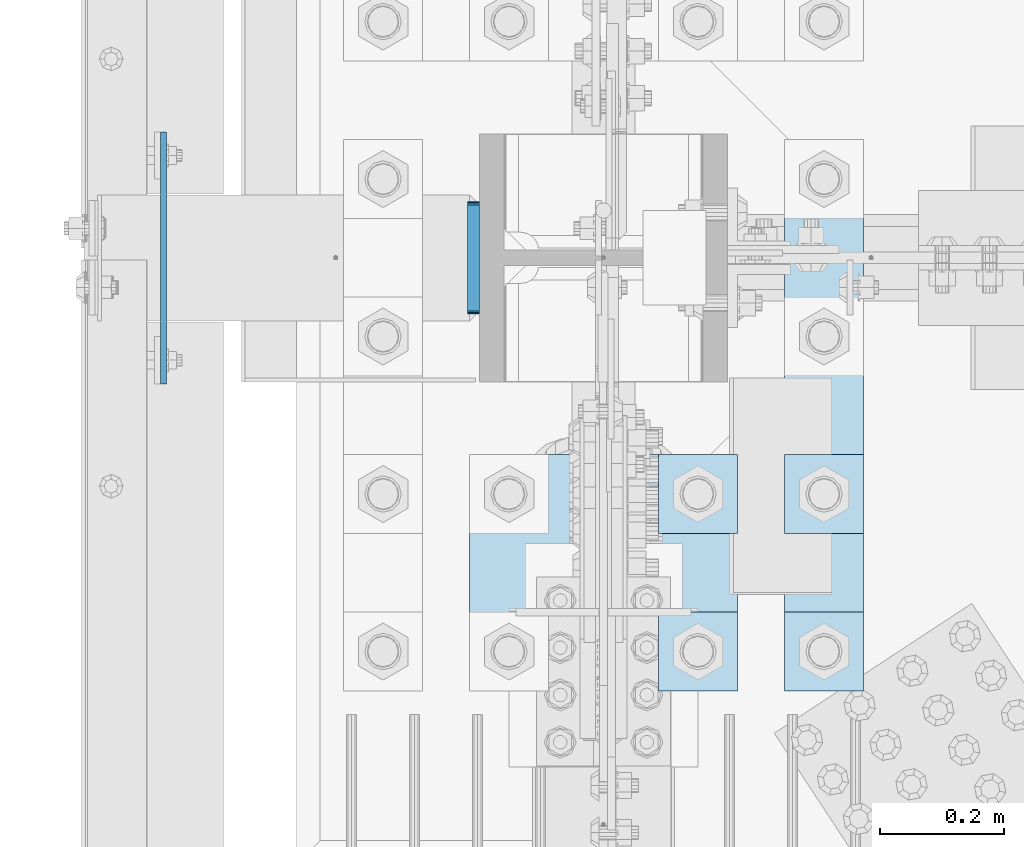
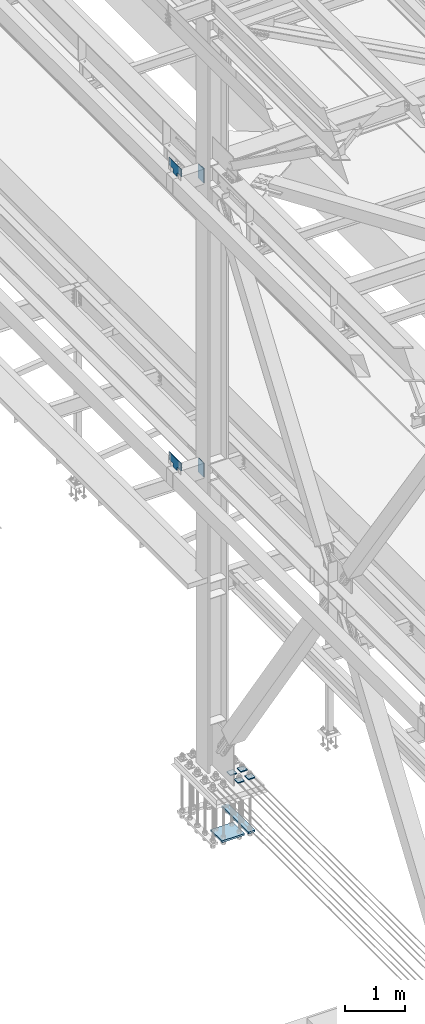
# One storey, part 3270 of 3843: 10 plates, 2 elements without a shape of their own.
"""IFC2X3 building model written with IfcOpenShell, lengths in millimetres."""

from ifc_helpers import new_model, si_unit, frame, origin_with_axes, place, context, subcontext, project, spatial, faceted_brep, material, type_object, element, aggregate, save


model = new_model("IFC2X3")

# Units and contexts
model_context = context("Model", 3, precision=1e-05, world=origin_with_axes())
body_context = subcontext(model_context, "Body", "Model", "MODEL_VIEW")
ifc_project = project(units=[si_unit("LENGTHUNIT", "METRE", prefix="MILLI"), si_unit("AREAUNIT", "SQUARE_METRE"), si_unit("VOLUMEUNIT", "CUBIC_METRE"), si_unit("MASSUNIT", "GRAM", prefix="KILO"), si_unit("TIMEUNIT", "SECOND"), si_unit("PLANEANGLEUNIT", "RADIAN"), si_unit("SOLIDANGLEUNIT", "STERADIAN"), si_unit("THERMODYNAMICTEMPERATUREUNIT", "DEGREE_CELSIUS"), si_unit("LUMINOUSINTENSITYUNIT", "LUMEN")], contexts=[model_context])

# Site, building, storey
site_placement = place(None, origin_with_axes())
site = spatial("IfcSite", under=ifc_project, at=site_placement, CompositionType="ELEMENT")
building_placement = place(site_placement, origin_with_axes())
building = spatial("IfcBuilding", under=site, at=building_placement, Name="Undefined", CompositionType="ELEMENT")
storey_placement = place(building_placement, origin_with_axes())
storey = spatial("IfcBuildingStorey", under=building, at=storey_placement, Name="Undefined", CompositionType="ELEMENT", Elevation=0.0)

# Assembly, plates
assembly_1_placement = place(storey_placement, origin_with_axes())
assembly_1 = element("IfcElementAssembly", 1, at=assembly_1_placement, inside=storey, Name="COLUMN", AssemblyPlace="NOTDEFINED", PredefinedType="RIGID_FRAME")
ifc_material = material(Name="STEEL/A572-50")
plate_type_1 = type_object("IfcPlateType", PredefinedType="NOTDEFINED")
plate_1_placement = place(assembly_1_placement, frame((35866.3875, 58978.8, 36404.55), z_axis=(0.0, 0.0, 1.0), x_axis=(0.0, -1.0, 0.0)))
plate_1 = element("IfcPlate", 2, at=plate_1_placement, type_object=plate_type_1, material=ifc_material, Name="PLATE", context=body_context, shape_type="Brep", body=[
    faceted_brep([(0.0, -4.76249999999709, 0.0), (-3.49245965480804e-10, -4.76249999999709, 76.1999999999462), (-3.49245965480804e-10, 4.76249999999709, 76.1999999999462), (0.0, 4.76249999999709, 0.0), (-139.699996948242, -4.76249999999709, 76.1999969482422), (-139.699996948242, 4.76249999999709, 76.1999969482422), (-139.699996948242, -4.76249999999709, 228.600006103516), (-139.699996948242, 4.76249999999709, 228.600006103516), (266.700012207031, -4.76249999999709, 228.600006103516), (266.700012207031, 4.76249999999709, 228.600006103516), (266.700012207031, -4.76249999999709, 76.1999969482422), (266.700012207031, 4.76249999999709, 76.1999969482422), (126.999992370605, -4.76249999999709, 76.1999969482422), (126.999992370605, 4.76249999999709, 76.1999969482422), (126.999992370605, -4.76249999999709, 0.0), (126.999992370605, 4.76249999999709, 0.0)], [[[0, 1, 2, 3]], [[1, 4, 5, 2]], [[4, 6, 7, 5]], [[6, 8, 9, 7]], [[8, 10, 11, 9]], [[10, 12, 13, 11]], [[12, 14, 15, 13]], [[14, 0, 3, 15]], [[5, 7, 9, 11, 13, 15, 3, 2]], [[14, 12, 10, 8, 6, 4, 1, 0]]]),
])
plate_2_placement = place(assembly_1_placement, frame((35866.3875, 58978.8, 42367.2), z_axis=(0.0, 0.0, 1.0), x_axis=(0.0, -1.0, 0.0)))
plate_2 = element("IfcPlate", 3, at=plate_2_placement, type_object=plate_type_1, material=ifc_material, Name="PLATE", context=body_context, shape_type="Brep", body=[
    faceted_brep([(0.0, -4.76249999999709, 0.0), (-3.49245965480804e-10, -4.76249999999709, 76.1999999999462), (-3.49245965480804e-10, 4.76249999999709, 76.1999999999462), (0.0, 4.76249999999709, 0.0), (-139.699996948242, -4.76249999999709, 76.1999969482422), (-139.699996948242, 4.76249999999709, 76.1999969482422), (-139.699996948242, -4.76249999999709, 228.600006103516), (-139.699996948242, 4.76249999999709, 228.600006103516), (266.700012207031, -4.76249999999709, 228.600006103516), (266.700012207031, 4.76249999999709, 228.600006103516), (266.700012207031, -4.76249999999709, 76.1999969482422), (266.700012207031, 4.76249999999709, 76.1999969482422), (126.999992370605, -4.76249999999709, 76.1999969482422), (126.999992370605, 4.76249999999709, 76.1999969482422), (126.999992370605, -4.76249999999709, 0.0), (126.999992370605, 4.76249999999709, 0.0)], [[[0, 1, 2, 3]], [[1, 4, 5, 2]], [[4, 6, 7, 5]], [[6, 8, 9, 7]], [[8, 10, 11, 9]], [[10, 12, 13, 11]], [[12, 14, 15, 13]], [[14, 0, 3, 15]], [[5, 7, 9, 11, 13, 15, 3, 2]], [[14, 12, 10, 8, 6, 4, 1, 0]]]),
])
plate_type_2 = type_object("IfcPlateType", PredefinedType="NOTDEFINED")
plate_3_placement = place(assembly_1_placement, frame((36366.45, 58824.8125, 42356.4551879883), z_axis=(0.0, 1.0, 0.0), x_axis=(0.0, 0.0, -1.0)))
plate_3 = element("IfcPlate", 4, at=plate_3_placement, type_object=plate_type_2, material=ifc_material, Name="PLATE", context=body_context, shape_type="Brep", body=[
    faceted_brep([(-8.22591685395256e-13, -9.52499999999854, 7.9375), (0.0, -9.52499999999418, 173.037499999991), (0.0, 9.52499999999418, 173.037499999991), (0.0, 9.52499999999418, 7.9375), (0.604206210693519, -9.52499999999418, 176.075049744395), (0.604206210693519, 9.52499999999418, 176.075049744395), (2.32483992433117, -9.52499999999418, 178.65016007566), (2.32483992433117, 9.52499999999418, 178.65016007566), (4.89995025560347, -9.52499999999418, 180.370793789305), (4.89995025560347, 9.52499999999418, 180.370793789305), (7.9375, -9.52499999999418, 180.974999999991), (7.9375, 9.52499999999418, 180.974999999991), (274.637499999997, -9.52499999999418, 180.974999999991), (274.637499999997, 9.52499999999418, 180.974999999991), (277.675049744394, -9.52499999999418, 180.370793789305), (277.675049744394, 9.52499999999418, 180.370793789305), (280.250160075666, -9.52499999999418, 178.65016007566), (280.250160075666, 9.52499999999418, 178.65016007566), (281.970793789304, -9.52499999999418, 176.075049744395), (281.970793789304, 9.52499999999418, 176.075049744395), (282.574999999997, -9.52499999999418, 173.037499999991), (282.574999999997, 9.52499999999418, 173.037499999991), (282.574999999997, -9.52499999999418, 7.9375), (282.574999999997, 9.52499999999418, 7.9375), (281.970793789304, -9.52499999999418, 4.8999502555962), (281.970793789304, 9.52499999999418, 4.8999502555962), (280.250160075666, -9.52499999999418, 2.32483992433117), (280.250160075666, 9.52499999999418, 2.32483992433117), (277.675049744394, -9.52499999999418, 0.604206210686243), (277.675049744394, 9.52499999999418, 0.604206210686243), (274.637499999997, -9.52499999999418, 0.0), (274.637499999997, 9.52499999999418, 0.0), (7.9375, -9.52499999999854, 0.0), (7.9375, 9.52499999999418, 0.0), (4.8999502555962, -9.52499999999418, 0.604206210693519), (4.8999502555962, 9.52499999999418, 0.604206210693519), (2.32483992433117, -9.52499999999418, 2.32483992433117), (2.32483992433117, 9.52499999999418, 2.32483992433117), (0.604206210686243, -9.52499999999418, 4.89995025560347), (0.604206210686243, 9.52499999999418, 4.89995025560347)], [[[0, 1, 2, 3]], [[1, 4, 5, 2]], [[4, 6, 7, 5]], [[6, 8, 9, 7]], [[8, 10, 11, 9]], [[10, 12, 13, 11]], [[12, 14, 15, 13]], [[14, 16, 17, 15]], [[16, 18, 19, 17]], [[18, 20, 21, 19]], [[20, 22, 23, 21]], [[22, 24, 25, 23]], [[24, 26, 27, 25]], [[26, 28, 29, 27]], [[28, 30, 31, 29]], [[30, 32, 33, 31]], [[32, 34, 35, 33]], [[34, 36, 37, 35]], [[36, 38, 39, 37]], [[38, 0, 3, 39]], [[5, 7, 9, 11, 13, 15, 17, 19, 21, 23, 25, 27, 29, 31, 33, 35, 37, 39, 3, 2]], [[38, 36, 34, 32, 30, 28, 26, 24, 22, 20, 18, 16, 14, 12, 10, 8, 6, 4, 1, 0]]]),
])
plate_4_placement = place(assembly_1_placement, frame((36366.45, 58824.8125, 36393.4375), z_axis=(0.0, 1.0, 0.0), x_axis=(0.0, 0.0, -1.0)))
plate_4 = element("IfcPlate", 5, at=plate_4_placement, type_object=plate_type_2, material=ifc_material, Name="PLATE", context=body_context, shape_type="Brep", body=[
    faceted_brep([(-8.22591685395256e-13, -9.52499999999854, 7.9375), (0.0, -9.52499999999418, 173.037499999991), (0.0, 9.52499999999418, 173.037499999991), (0.0, 9.52499999999418, 7.9375), (0.604206210693519, -9.52499999999418, 176.075049744395), (0.604206210693519, 9.52499999999418, 176.075049744395), (2.32483992433117, -9.52499999999418, 178.65016007566), (2.32483992433117, 9.52499999999418, 178.65016007566), (4.89995025560347, -9.52499999999418, 180.370793789305), (4.89995025560347, 9.52499999999418, 180.370793789305), (7.9375, -9.52499999999418, 180.974999999991), (7.9375, 9.52499999999418, 180.974999999991), (274.637499999997, -9.52499999999418, 180.974999999991), (274.637499999997, 9.52499999999418, 180.974999999991), (277.675049744394, -9.52499999999418, 180.370793789305), (277.675049744394, 9.52499999999418, 180.370793789305), (280.250160075666, -9.52499999999418, 178.65016007566), (280.250160075666, 9.52499999999418, 178.65016007566), (281.970793789304, -9.52499999999418, 176.075049744395), (281.970793789304, 9.52499999999418, 176.075049744395), (282.574999999997, -9.52499999999418, 173.037499999991), (282.574999999997, 9.52499999999418, 173.037499999991), (282.574999999997, -9.52499999999418, 7.9375), (282.574999999997, 9.52499999999418, 7.9375), (281.970793789304, -9.52499999999418, 4.8999502555962), (281.970793789304, 9.52499999999418, 4.8999502555962), (280.250160075666, -9.52499999999418, 2.32483992433117), (280.250160075666, 9.52499999999418, 2.32483992433117), (277.675049744394, -9.52499999999418, 0.604206210686243), (277.675049744394, 9.52499999999418, 0.604206210686243), (274.637499999997, -9.52499999999418, 0.0), (274.637499999997, 9.52499999999418, 0.0), (7.9375, -9.52499999999854, 0.0), (7.9375, 9.52499999999418, 0.0), (4.8999502555962, -9.52499999999418, 0.604206210693519), (4.8999502555962, 9.52499999999418, 0.604206210693519), (2.32483992433117, -9.52499999999418, 2.32483992433117), (2.32483992433117, 9.52499999999418, 2.32483992433117), (0.604206210686243, -9.52499999999418, 4.89995025560347), (0.604206210686243, 9.52499999999418, 4.89995025560347)], [[[0, 1, 2, 3]], [[1, 4, 5, 2]], [[4, 6, 7, 5]], [[6, 8, 9, 7]], [[8, 10, 11, 9]], [[10, 12, 13, 11]], [[12, 14, 15, 13]], [[14, 16, 17, 15]], [[16, 18, 19, 17]], [[18, 20, 21, 19]], [[20, 22, 23, 21]], [[22, 24, 25, 23]], [[24, 26, 27, 25]], [[26, 28, 29, 27]], [[28, 30, 31, 29]], [[30, 32, 33, 31]], [[32, 34, 35, 33]], [[34, 36, 37, 35]], [[36, 38, 39, 37]], [[38, 0, 3, 39]], [[5, 7, 9, 11, 13, 15, 17, 19, 21, 23, 25, 27, 29, 31, 33, 35, 37, 39, 3, 2]], [[38, 36, 34, 32, 30, 28, 26, 24, 22, 20, 18, 16, 14, 12, 10, 8, 6, 4, 1, 0]]]),
])
aggregate(assembly_1, [plate_3, plate_4, plate_1, plate_2])

assembly_2_placement = place(storey_placement, origin_with_axes())
assembly_2 = element("IfcElementAssembly", 6, at=assembly_2_placement, inside=storey, Name="TEMPLATE", AssemblyPlace="NOTDEFINED", PredefinedType="RIGID_FRAME")
plate_type_3 = type_object("IfcPlateType", PredefinedType="NOTDEFINED")
plate_5_placement = place(assembly_2_placement, frame((36868.1, 58343.8, 30172.025), z_axis=(0.0, -1.0, 0.0), x_axis=(1.0, 0.0, 0.0)))
plate_5 = element("IfcPlate", 7, at=plate_5_placement, type_object=plate_type_3, material=ifc_material, Name="Washer Plate", context=body_context, shape_type="Brep", body=[
    faceted_brep([(0.0, -9.52500000000146, 0.0), (0.0, -9.52499999999418, 127.0), (0.0, 9.52499999999418, 127.0), (0.0, 9.52500000000146, 0.0), (127.0, -9.52500000000146, 127.0), (127.0, 9.52500000000146, 127.0), (127.0, -9.52500000000146, 0.0), (127.0, 9.52500000000146, 0.0)], [[[0, 1, 2, 3]], [[1, 4, 5, 2]], [[4, 6, 7, 5]], [[6, 0, 3, 7]], [[5, 7, 3, 2]], [[6, 4, 1, 0]]]),
])
plate_6_placement = place(assembly_2_placement, frame((36868.1, 58597.8, 30172.025), z_axis=(0.0, -1.0, 0.0), x_axis=(1.0, 0.0, 0.0)))
plate_6 = element("IfcPlate", 8, at=plate_6_placement, type_object=plate_type_3, material=ifc_material, Name="Washer Plate", context=body_context, shape_type="Brep", body=[
    faceted_brep([(0.0, -9.52500000000146, 0.0), (0.0, -9.52499999999418, 127.0), (0.0, 9.52499999999418, 127.0), (0.0, 9.52500000000146, 0.0), (127.0, -9.52500000000146, 127.0), (127.0, 9.52500000000146, 127.0), (127.0, -9.52500000000146, 0.0), (127.0, 9.52500000000146, 0.0)], [[[0, 1, 2, 3]], [[1, 4, 5, 2]], [[4, 6, 7, 5]], [[6, 0, 3, 7]], [[5, 7, 3, 2]], [[6, 4, 1, 0]]]),
])
plate_7_placement = place(assembly_2_placement, frame((36664.9, 58343.8, 30172.025), z_axis=(0.0, -1.0, 0.0), x_axis=(1.0, 0.0, 0.0)))
plate_7 = element("IfcPlate", 9, at=plate_7_placement, type_object=plate_type_3, material=ifc_material, Name="Washer Plate", context=body_context, shape_type="Brep", body=[
    faceted_brep([(0.0, -9.52500000000146, 0.0), (0.0, -9.52499999999418, 127.0), (0.0, 9.52499999999418, 127.0), (0.0, 9.52500000000146, 0.0), (127.0, -9.52500000000146, 127.0), (127.0, 9.52500000000146, 127.0), (127.0, -9.52500000000146, 0.0), (127.0, 9.52500000000146, 0.0)], [[[0, 1, 2, 3]], [[1, 4, 5, 2]], [[4, 6, 7, 5]], [[6, 0, 3, 7]], [[5, 7, 3, 2]], [[6, 4, 1, 0]]]),
])
plate_8_placement = place(assembly_2_placement, frame((36664.9, 58597.8, 30172.025), z_axis=(0.0, -1.0, 0.0), x_axis=(1.0, 0.0, 0.0)))
plate_8 = element("IfcPlate", 10, at=plate_8_placement, type_object=plate_type_3, material=ifc_material, Name="Washer Plate", context=body_context, shape_type="Brep", body=[
    faceted_brep([(0.0, -9.52500000000146, 0.0), (0.0, -9.52499999999418, 127.0), (0.0, 9.52499999999418, 127.0), (0.0, 9.52500000000146, 0.0), (127.0, -9.52500000000146, 127.0), (127.0, 9.52500000000146, 127.0), (127.0, -9.52500000000146, 0.0), (127.0, 9.52500000000146, 0.0)], [[[0, 1, 2, 3]], [[1, 4, 5, 2]], [[4, 6, 7, 5]], [[6, 0, 3, 7]], [[5, 7, 3, 2]], [[6, 4, 1, 0]]]),
])
plate_type_4 = type_object("IfcPlateType", PredefinedType="NOTDEFINED")
plate_9_placement = place(assembly_2_placement, frame((36868.1, 59105.8, 29089.35), z_axis=(0.0, -1.0, 0.0), x_axis=(1.0, 0.0, 0.0)))
plate_9 = element("IfcPlate", 11, at=plate_9_placement, type_object=plate_type_4, material=ifc_material, Name="PLATE", context=body_context, shape_type="Brep", body=[
    faceted_brep([(0.0, -19.0500000000029, 0.0), (-7.27595761418343e-12, -19.0499999999993, 889.0), (-7.27595761418343e-12, 19.0499999999993, 889.0), (0.0, 19.0500000000029, 0.0), (127.0, -19.0499999999993, 889.0), (127.0, 19.0499999999993, 889.0), (127.0, -19.0499999999993, 0.0), (127.0, 19.0499999999993, 0.0)], [[[0, 1, 2, 3]], [[1, 4, 5, 2]], [[4, 6, 7, 5]], [[6, 0, 3, 7]], [[5, 7, 3, 2]], [[6, 4, 1, 0]]]),
])
plate_type_5 = type_object("IfcPlateType", PredefinedType="NOTDEFINED")
plate_10_placement = place(assembly_2_placement, frame((36791.9, 58597.8, 29089.35), z_axis=(-1.0, 0.0, 0.0), x_axis=(0.0, -1.0, 0.0)))
plate_10 = element("IfcPlate", 12, at=plate_10_placement, type_object=plate_type_5, material=ifc_material, Name="PLATE", context=body_context, shape_type="Brep", body=[
    faceted_brep([(0.0, -19.0500000000029, 0.0), (0.0, -19.0499999999993, 431.799987792969), (0.0, 19.0499999999993, 431.799987792969), (0.0, 19.0500000000029, 0.0), (381.0, -19.0499999999993, 431.799987792969), (381.0, 19.0499999999993, 431.799987792969), (381.0, -19.0499999999993, 0.0), (381.0, 19.0499999999993, 0.0)], [[[0, 1, 2, 3]], [[1, 4, 5, 2]], [[4, 6, 7, 5]], [[6, 0, 3, 7]], [[5, 7, 3, 2]], [[6, 4, 1, 0]]]),
])
aggregate(assembly_2, [plate_5, plate_6, plate_7, plate_8, plate_10, plate_9])

save(model, "model.ifc")
